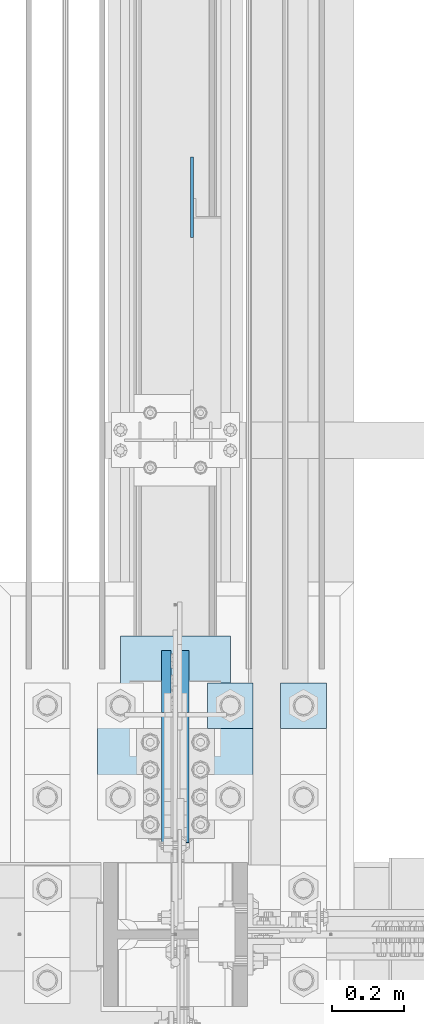
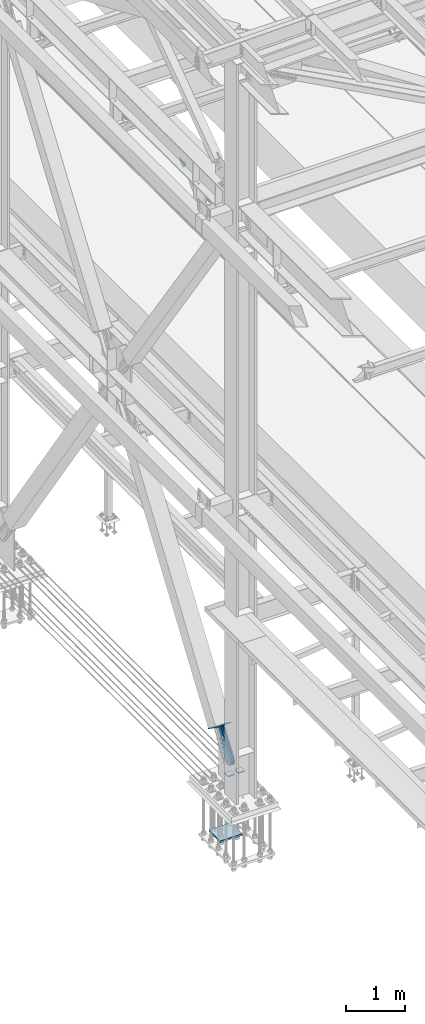
# One storey, part 3345 of 3843: 7 plates, 5 elements without a shape of their own.
"""IFC2X3 building model written with IfcOpenShell, lengths in millimetres."""

from ifc_helpers import new_model, si_unit, frame, origin_with_axes, place, context, subcontext, project, spatial, faceted_brep, material, type_object, element, aggregate, save


model = new_model("IFC2X3")

# Units and contexts
model_context = context("Model", 3, precision=1e-05, world=origin_with_axes())
body_context = subcontext(model_context, "Body", "Model", "MODEL_VIEW")
ifc_project = project(units=[si_unit("LENGTHUNIT", "METRE", prefix="MILLI"), si_unit("AREAUNIT", "SQUARE_METRE"), si_unit("VOLUMEUNIT", "CUBIC_METRE"), si_unit("MASSUNIT", "GRAM", prefix="KILO"), si_unit("TIMEUNIT", "SECOND"), si_unit("PLANEANGLEUNIT", "RADIAN"), si_unit("SOLIDANGLEUNIT", "STERADIAN"), si_unit("THERMODYNAMICTEMPERATUREUNIT", "DEGREE_CELSIUS"), si_unit("LUMINOUSINTENSITYUNIT", "LUMEN")], contexts=[model_context])

# Site, building, storey
site_placement = place(None, origin_with_axes())
site = spatial("IfcSite", under=ifc_project, at=site_placement, CompositionType="ELEMENT")
building_placement = place(site_placement, origin_with_axes())
building = spatial("IfcBuilding", under=site, at=building_placement, Name="Undefined", CompositionType="ELEMENT")
storey_placement = place(building_placement, origin_with_axes())
storey = spatial("IfcBuildingStorey", under=building, at=storey_placement, Name="Undefined", CompositionType="ELEMENT", Elevation=0.0)

# Assembly, plate
assembly_1_placement = place(storey_placement, origin_with_axes())
assembly_1 = element("IfcElementAssembly", 1, at=assembly_1_placement, inside=storey, Name="Plate", AssemblyPlace="NOTDEFINED", PredefinedType="RIGID_FRAME")
ifc_material_1 = material(Name="STEEL/A36")
plate_type_1 = type_object("IfcPlateType", PredefinedType="NOTDEFINED")
plate_1_placement = place(assembly_1_placement, frame((36728.4, 68098.1193500348, 31097.2996620158), z_axis=(0.0, -0.824568408012538, 0.565762265008607), x_axis=(-1.0, 0.0, 0.0)))
plate_1 = element("IfcPlate", 2, at=plate_1_placement, type_object=plate_type_1, material=ifc_material_1, Name="Plate", context=body_context, shape_type="Brep", body=[
    faceted_brep([(0.0, -3.17499999999927, 0.0), (0.0, -3.17499999999927, 304.800000000003), (0.0, 3.17499999999927, 304.800000000003), (0.0, 3.17499999999927, 0.0), (304.800000000003, -3.17500000019936, 304.800000010334), (304.800000000003, 3.17499999980646, 304.800000010323), (304.800000000003, -3.17500000000291, 2.72848410531878e-12), (304.800000000003, 3.17499999999563, -4.54747350886464e-12)], [[[0, 1, 2, 3]], [[1, 4, 5, 2]], [[4, 6, 7, 5]], [[6, 0, 3, 7]], [[5, 7, 3, 2]], [[6, 4, 1, 0]]]),
])
aggregate(assembly_1, [plate_1])

assembly_2_placement = place(storey_placement, origin_with_axes())
assembly_2 = element("IfcElementAssembly", 3, at=assembly_2_placement, inside=storey, AssemblyPlace="NOTDEFINED", PredefinedType="RIGID_FRAME")
plate_type_2 = type_object("IfcPlateType", PredefinedType="NOTDEFINED")
plate_2_placement = place(assembly_2_placement, frame((36550.6, 68021.0399019887, 31069.3258072585), z_axis=(0.0, -0.824568408012538, 0.565762265008607), x_axis=(0.0, 0.5657622650086, 0.824568408012542)))
plate_2 = element("IfcPlate", 4, at=plate_2_placement, type_object=plate_type_2, material=ifc_material_1, context=body_context, shape_type="Brep", body=[
    faceted_brep([(0.0, -12.6999999999971, 0.0), (-101.599999998083, -12.6999999999971, -9.63072631921386), (-101.599999998083, 12.6999999999971, -9.63072631921386), (0.0, 12.6999999999971, 0.0), (-523.136744945159, -12.6999999999971, -9.63072631946125), (-523.136744945159, 12.6999999999971, -9.63072631946125), (-566.877462432296, -12.6999999999971, -0.93015665312123), (-566.877462432296, 12.6999999999971, -0.93015665312123), (-603.959052192533, -12.6999999999971, 23.8469694851374), (-603.959052192533, 12.6999999999971, 23.8469694851374), (-628.736178330275, -12.6999999999971, 60.92855924592), (-628.736178330275, 12.6999999999971, 60.92855924592), (-637.436747996218, -12.6999999999971, 104.669270634855), (-637.436747996218, 12.6999999999971, 104.669270634855), (-628.736178329733, -12.6999999999971, 148.409988122046), (-628.736178329733, 12.6999999999971, 148.409988122046), (-603.959052191802, -12.6999999999971, 185.491577882363), (-603.959052191802, 12.6999999999971, 185.491577882363), (-566.877462431685, -12.6999999999971, 210.268704020258), (-566.877462431685, 12.6999999999971, 210.268704020258), (-523.136747997525, -12.6999999999971, 218.969273686525), (-523.136747997525, 12.6999999999971, 218.969273686525), (-101.599999996293, -12.6999999999971, 218.969273686773), (-101.599999996293, 12.6999999999971, 218.969273686773), (1.66073732543737e-09, -12.6999999999971, 209.33854736769), (1.66073732543737e-09, 12.6999999999971, 209.33854736769), (69.8500000003169, -12.6999999999971, 209.338547367734), (69.8500000003169, 12.6999999999971, 209.338547367734), (69.8499999986579, -12.6999999999971, 4.36557456851006e-11), (69.8499999986579, 12.6999999999971, 4.36557456851006e-11)], [[[0, 1, 2, 3]], [[1, 4, 5, 2]], [[4, 6, 7, 5]], [[6, 8, 9, 7]], [[8, 10, 11, 9]], [[10, 12, 13, 11]], [[12, 14, 15, 13]], [[14, 16, 17, 15]], [[16, 18, 19, 17]], [[18, 20, 21, 19]], [[20, 22, 23, 21]], [[22, 24, 25, 23]], [[24, 26, 27, 25]], [[26, 28, 29, 27]], [[28, 0, 3, 29]], [[5, 7, 9, 11, 13, 15, 17, 19, 21, 23, 25, 27, 29, 3, 2]], [[28, 26, 24, 22, 20, 18, 16, 14, 12, 10, 8, 6, 4, 1, 0]]]),
])
aggregate(assembly_2, [plate_2])

assembly_3_placement = place(storey_placement, origin_with_axes())
assembly_3 = element("IfcElementAssembly", 5, at=assembly_3_placement, inside=storey, AssemblyPlace="NOTDEFINED", PredefinedType="RIGID_FRAME")
plate_3_placement = place(assembly_3_placement, frame((36601.4, 68021.0399019887, 31069.3258072585), z_axis=(0.0, -0.824568408012538, 0.565762265008607), x_axis=(0.0, 0.5657622650086, 0.824568408012542)))
plate_3 = element("IfcPlate", 6, at=plate_3_placement, type_object=plate_type_2, material=ifc_material_1, context=body_context, shape_type="Brep", body=[
    faceted_brep([(0.0, -12.6999999999971, 0.0), (-101.599999998083, -12.6999999999971, -9.63072631921386), (-101.599999998083, 12.6999999999971, -9.63072631921386), (0.0, 12.6999999999971, 0.0), (-523.136744945159, -12.6999999999971, -9.63072631946125), (-523.136744945159, 12.6999999999971, -9.63072631946125), (-566.877462432296, -12.6999999999971, -0.93015665312123), (-566.877462432296, 12.6999999999971, -0.93015665312123), (-603.959052192533, -12.6999999999971, 23.8469694851374), (-603.959052192533, 12.6999999999971, 23.8469694851374), (-628.736178330275, -12.6999999999971, 60.92855924592), (-628.736178330275, 12.6999999999971, 60.92855924592), (-637.436747996218, -12.6999999999971, 104.669270634855), (-637.436747996218, 12.6999999999971, 104.669270634855), (-628.736178329733, -12.6999999999971, 148.409988122046), (-628.736178329733, 12.6999999999971, 148.409988122046), (-603.959052191802, -12.6999999999971, 185.491577882363), (-603.959052191802, 12.6999999999971, 185.491577882363), (-566.877462431685, -12.6999999999971, 210.268704020258), (-566.877462431685, 12.6999999999971, 210.268704020258), (-523.136747997525, -12.6999999999971, 218.969273686525), (-523.136747997525, 12.6999999999971, 218.969273686525), (-101.599999996293, -12.6999999999971, 218.969273686773), (-101.599999996293, 12.6999999999971, 218.969273686773), (1.66073732543737e-09, -12.6999999999971, 209.33854736769), (1.66073732543737e-09, 12.6999999999971, 209.33854736769), (69.8500000003169, -12.6999999999971, 209.338547367734), (69.8500000003169, 12.6999999999971, 209.338547367734), (69.8499999986579, -12.6999999999971, 4.36557456851006e-11), (69.8499999986579, 12.6999999999971, 4.36557456851006e-11)], [[[0, 1, 2, 3]], [[1, 4, 5, 2]], [[4, 6, 7, 5]], [[6, 8, 9, 7]], [[8, 10, 11, 9]], [[10, 12, 13, 11]], [[12, 14, 15, 13]], [[14, 16, 17, 15]], [[16, 18, 19, 17]], [[18, 20, 21, 19]], [[20, 22, 23, 21]], [[22, 24, 25, 23]], [[24, 26, 27, 25]], [[26, 28, 29, 27]], [[28, 0, 3, 29]], [[5, 7, 9, 11, 13, 15, 17, 19, 21, 23, 25, 27, 29, 3, 2]], [[28, 26, 24, 22, 20, 18, 16, 14, 12, 10, 8, 6, 4, 1, 0]]]),
])
aggregate(assembly_3, [plate_3])

assembly_4_placement = place(storey_placement, origin_with_axes())
assembly_4 = element("IfcElementAssembly", 7, at=assembly_4_placement, inside=storey, Name="BEAM", AssemblyPlace="NOTDEFINED", PredefinedType="RIGID_FRAME")
ifc_material_2 = material(Name="STEEL/A572-50")
plate_type_3 = type_object("IfcPlateType", PredefinedType="NOTDEFINED")
plate_4_placement = place(assembly_4_placement, frame((36622.0375, 69428.7210237611, 41995.7250011383), z_axis=(0.0, -0.707106781186682, 0.707106781186413), x_axis=(0.0, -0.707106781186548, -0.707106781186548)))
plate_4 = element("IfcPlate", 8, at=plate_4_placement, type_object=plate_type_3, material=ifc_material_2, Name="PLATE", context=body_context, shape_type="Brep", body=[
    faceted_brep([(0.0, -4.76249999999709, 0.0), (157.726597423803, -4.76249999999709, 157.726601438866), (157.726597423803, 4.76249999999709, 157.726601438866), (0.0, 4.76249999999709, 0.0), (188.387110059113, -4.76249999999709, 127.066089584019), (188.387110059113, 4.76249999999709, 127.066089584019), (188.387111679331, -4.76249999999709, 1.09139364212751e-10), (188.387111679331, 4.76249999999709, 1.09139364212751e-10)], [[[0, 1, 2, 3]], [[1, 4, 5, 2]], [[4, 6, 7, 5]], [[6, 0, 3, 7]], [[5, 7, 3, 2]], [[6, 4, 1, 0]]]),
])
aggregate(assembly_4, [plate_4])

# Assembly, plates
assembly_5_placement = place(storey_placement, origin_with_axes())
assembly_5 = element("IfcElementAssembly", 9, at=assembly_5_placement, inside=storey, Name="TEMPLATE", AssemblyPlace="NOTDEFINED", PredefinedType="RIGID_FRAME")
plate_type_4 = type_object("IfcPlateType", PredefinedType="NOTDEFINED")
plate_5_placement = place(assembly_5_placement, frame((36868.1, 67970.4, 30172.025), z_axis=(0.0, -1.0, 0.0), x_axis=(1.0, 0.0, 0.0)))
plate_5 = element("IfcPlate", 10, at=plate_5_placement, type_object=plate_type_4, material=ifc_material_2, Name="Washer Plate", context=body_context, shape_type="Brep", body=[
    faceted_brep([(0.0, -9.52500000000146, 0.0), (0.0, -9.52499999999418, 127.0), (0.0, 9.52499999999418, 127.0), (0.0, 9.52500000000146, 0.0), (127.0, -9.52500000000146, 127.0), (127.0, 9.52500000000146, 127.0), (127.0, -9.52500000000146, 0.0), (127.0, 9.52500000000146, 0.0)], [[[0, 1, 2, 3]], [[1, 4, 5, 2]], [[4, 6, 7, 5]], [[6, 0, 3, 7]], [[5, 7, 3, 2]], [[6, 4, 1, 0]]]),
])
plate_6_placement = place(assembly_5_placement, frame((36664.9, 67970.4, 30172.025), z_axis=(0.0, -1.0, 0.0), x_axis=(1.0, 0.0, 0.0)))
plate_6 = element("IfcPlate", 11, at=plate_6_placement, type_object=plate_type_4, material=ifc_material_2, Name="Washer Plate", context=body_context, shape_type="Brep", body=[
    faceted_brep([(0.0, -9.52500000000146, 0.0), (0.0, -9.52499999999418, 127.0), (0.0, 9.52499999999418, 127.0), (0.0, 9.52500000000146, 0.0), (127.0, -9.52500000000146, 127.0), (127.0, 9.52500000000146, 127.0), (127.0, -9.52500000000146, 0.0), (127.0, 9.52500000000146, 0.0)], [[[0, 1, 2, 3]], [[1, 4, 5, 2]], [[4, 6, 7, 5]], [[6, 0, 3, 7]], [[5, 7, 3, 2]], [[6, 4, 1, 0]]]),
])
plate_type_5 = type_object("IfcPlateType", PredefinedType="NOTDEFINED")
plate_7_placement = place(assembly_5_placement, frame((36791.9, 67589.4, 29089.35), z_axis=(-1.0, 0.0, 0.0), x_axis=(0.0, 1.0, 0.0)))
plate_7 = element("IfcPlate", 12, at=plate_7_placement, type_object=plate_type_5, material=ifc_material_2, Name="PLATE", context=body_context, shape_type="Brep", body=[
    faceted_brep([(0.0, -19.0500000000029, 0.0), (0.0, -19.0499999999993, 431.799987792969), (0.0, 19.0499999999993, 431.799987792969), (0.0, 19.0500000000029, 0.0), (381.0, -19.0499999999993, 431.799987792969), (381.0, 19.0499999999993, 431.799987792969), (381.0, -19.0499999999993, 0.0), (381.0, 19.0499999999993, 0.0)], [[[0, 1, 2, 3]], [[1, 4, 5, 2]], [[4, 6, 7, 5]], [[6, 0, 3, 7]], [[5, 7, 3, 2]], [[6, 4, 1, 0]]]),
])
aggregate(assembly_5, [plate_5, plate_6, plate_7])

save(model, "model.ifc")
